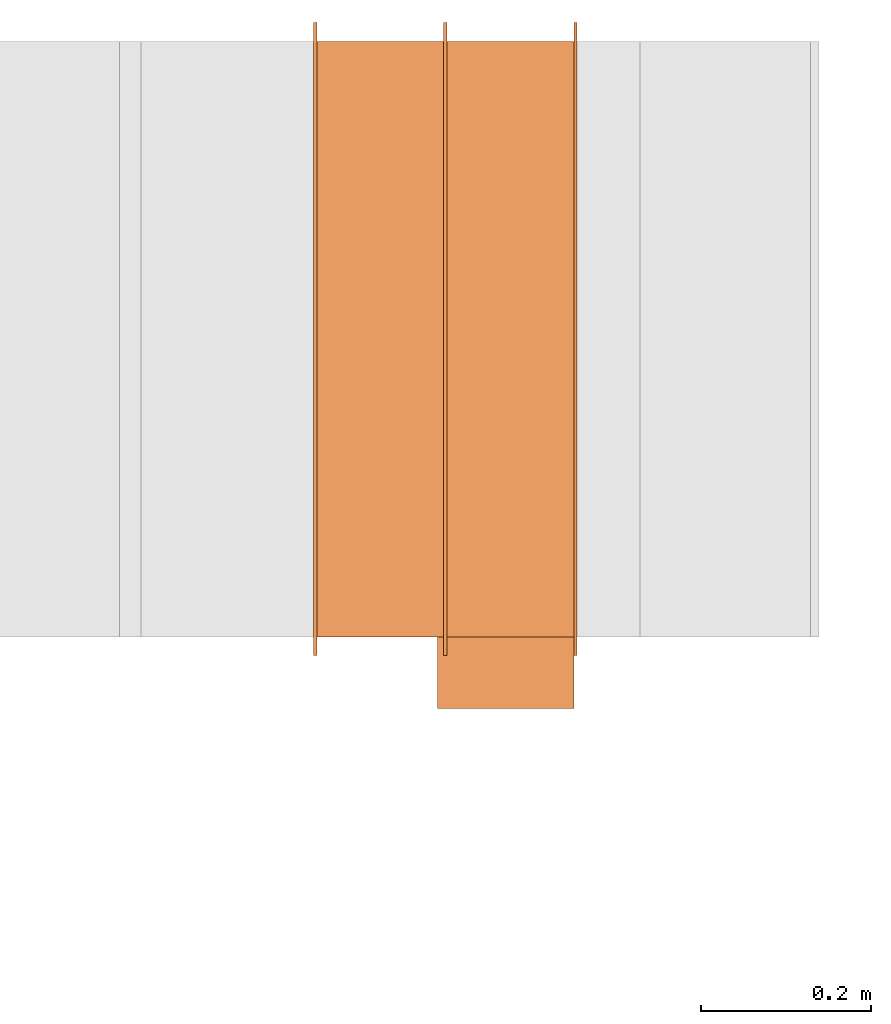
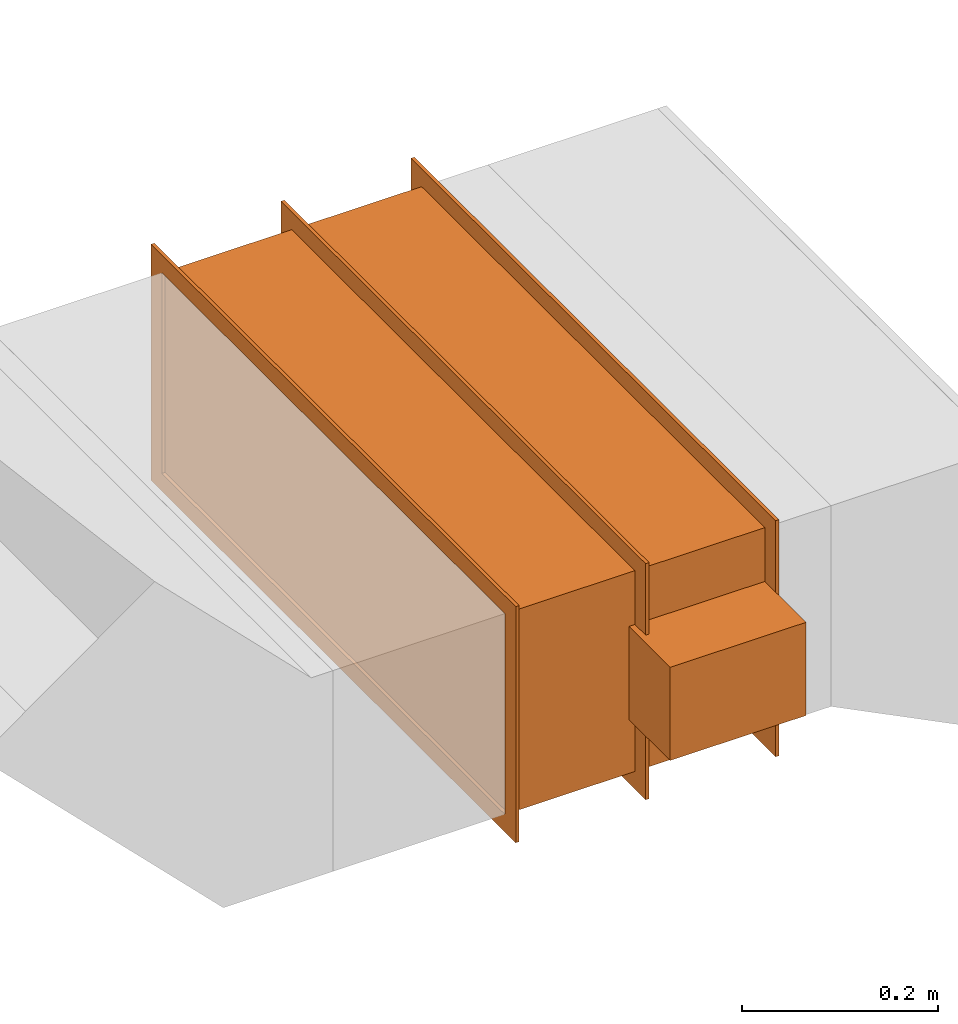
# One storey, part 2 of 2: 1 proxy.
"""IFC2X3 building model written with IfcOpenShell, lengths in millimetres."""

from ifc_helpers import new_model, entity, si_unit, converted_unit, derived_unit, direction, frame, origin, origin_2d_with_axis, place, context, subcontext, project, spatial, polyline, rectangle, outline, extrude, source, transform, mapped, type_object, type_shapes, element, save


model = new_model("IFC2X3")

# Units and contexts
model_context = context("Model", 3, precision=0.01, world=origin(), true_north=direction((6.12303176911189e-17, 1.0)))
body_context = subcontext(model_context, "Body", "Model", "MODEL_VIEW")
ifc_project = project(units=[si_unit("LENGTHUNIT", "METRE", prefix="MILLI"), si_unit("AREAUNIT", "SQUARE_METRE"), si_unit("VOLUMEUNIT", "CUBIC_METRE"), converted_unit("PLANEANGLEUNIT", "DEGREE", entity("IfcRatioMeasure", 0.0174532925199433), si_unit("PLANEANGLEUNIT", "RADIAN"), dimensions=[0, 0, 0, 0, 0, 0, 0]), si_unit("MASSUNIT", "GRAM", prefix="KILO"), derived_unit("MASSDENSITYUNIT", [(si_unit("MASSUNIT", "GRAM", prefix="KILO"), 1), (si_unit("LENGTHUNIT", "METRE"), -3)]), si_unit("TIMEUNIT", "SECOND"), si_unit("FREQUENCYUNIT", "HERTZ"), si_unit("THERMODYNAMICTEMPERATUREUNIT", "DEGREE_CELSIUS"), derived_unit("THERMALTRANSMITTANCEUNIT", [(si_unit("MASSUNIT", "GRAM", prefix="KILO"), 1), (si_unit("THERMODYNAMICTEMPERATUREUNIT", "KELVIN"), -1), (si_unit("TIMEUNIT", "SECOND"), -3)]), derived_unit("VOLUMETRICFLOWRATEUNIT", [(si_unit("LENGTHUNIT", "METRE"), 3), (si_unit("TIMEUNIT", "SECOND"), -1)]), si_unit("ELECTRICCURRENTUNIT", "AMPERE"), si_unit("ELECTRICVOLTAGEUNIT", "VOLT"), si_unit("POWERUNIT", "WATT"), si_unit("FORCEUNIT", "NEWTON", prefix="KILO"), si_unit("ILLUMINANCEUNIT", "LUX"), si_unit("LUMINOUSFLUXUNIT", "LUMEN"), si_unit("LUMINOUSINTENSITYUNIT", "CANDELA"), derived_unit("USERDEFINED", [(si_unit("MASSUNIT", "GRAM", prefix="KILO"), -1), (si_unit("LENGTHUNIT", "METRE"), -2), (si_unit("TIMEUNIT", "SECOND"), 3), (si_unit("LUMINOUSFLUXUNIT", "LUMEN"), 1)]), derived_unit("LINEARVELOCITYUNIT", [(si_unit("LENGTHUNIT", "METRE"), 1), (si_unit("TIMEUNIT", "SECOND"), -1)]), si_unit("PRESSUREUNIT", "PASCAL"), derived_unit("USERDEFINED", [(si_unit("LENGTHUNIT", "METRE"), -2), (si_unit("MASSUNIT", "GRAM", prefix="KILO"), 1), (si_unit("TIMEUNIT", "SECOND"), -2)])], contexts=[model_context])

# Site, building, storey
site_placement = place(None, origin())
site = spatial("IfcSite", under=ifc_project, at=site_placement, CompositionType="ELEMENT")
building_placement = place(site_placement, origin())
building = spatial("IfcBuilding", under=site, at=building_placement, CompositionType="ELEMENT")
storey_placement = place(building_placement, frame((0.0, 0.0, 16000.0)))
storey = spatial("IfcBuildingStorey", under=building, at=storey_placement, Name="04 Roof", CompositionType="ELEMENT", Elevation=16000.0)

# Proxy
building_element_proxy_type = type_object("IfcBuildingElementProxyType", Name="WK", PredefinedType="NOTDEFINED")
shared_shape = source(origin(), body_context, "Body", "SweptSolid", [
    extrude(outline(polyline([(-147.0, -372.0), (147.0, -372.0), (147.0, 372.0), (-147.0, 372.0), (-147.0, -372.0)]), holes=[polyline([(-125.0, -350.0), (-125.0, 350.0), (125.0, 350.0), (125.0, -350.0), (-125.0, -350.0)])]), frame((151.0, 0.0, 0.0), z_axis=(1.0, 0.0, 0.0), x_axis=(0.0, 0.0, -1.0)), (0.0, 0.0, 1.0), 4.0),
    extrude(outline(polyline([(-372.0, -147.0), (372.0, -147.0), (372.0, 147.0), (-372.0, 147.0), (-372.0, -147.0)]), holes=[polyline([(-350.0, -125.0), (-350.0, 125.0), (350.0, 125.0), (350.0, -125.0), (-350.0, -125.0)])]), frame((-155.0, 0.0, 0.0), z_axis=(1.0, 0.0, 0.0), x_axis=(0.0, -1.0, 0.0)), (0.0, 0.0, 1.0), 4.0),
    extrude(outline(polyline([(-372.0, -147.0), (372.0, -147.0), (372.0, 147.0), (-372.0, 147.0), (-372.0, -147.0)]), holes=[polyline([(-350.0, -125.0), (-350.0, 125.0), (350.0, 125.0), (350.0, -125.0), (-350.0, -125.0)])]), frame((-2.0, 0.0, 0.0), z_axis=(1.0, 0.0, 0.0), x_axis=(0.0, -1.0, 0.0)), (0.0, 0.0, 1.0), 4.0),
    extrude(rectangle(XDim=302.0, YDim=700.0, at=origin_2d_with_axis()), frame((0.0, 0.0, -125.0), z_axis=(0.0, 0.0, 1.0), x_axis=(-1.0, 0.0, 0.0)), (0.0, 0.0, 1.0), 250.0),
    extrude(rectangle(XDim=84.0, YDim=160.0, at=origin_2d_with_axis()), frame((71.0, -392.0, -58.0), z_axis=(0.0, 0.0, 1.0), x_axis=(0.0, -1.0, 0.0)), (0.0, 0.0, 1.0), 116.0),
])
type_shapes(building_element_proxy_type, [shared_shape])
proxy_placement = place(storey_placement, frame((27844.4309510203, -68831.23958514, 935.950526343523)))
element("IfcBuildingElementProxy", 1, at=proxy_placement, inside=storey, type_object=building_element_proxy_type, Name="WK25-0001:WK", ObjectType="WK25-0001:WK", context=body_context, shape_type="MappedRepresentation", body=[
    mapped(shared_shape, transform((0.0, 0.0, 0.0), scale=1.0)),
])

save(model, "model.ifc")
